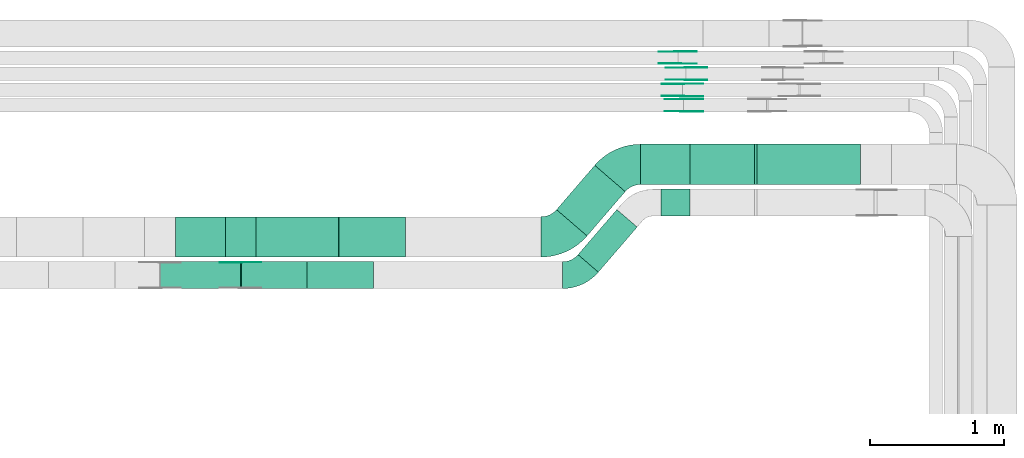
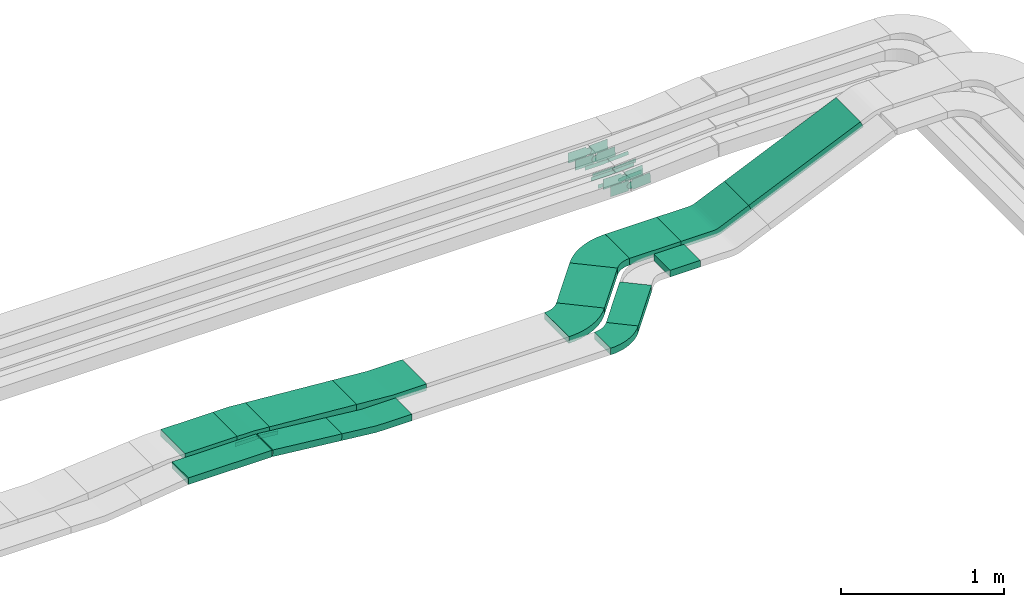
# One storey, part 20 of 28: 25 flow fittings, 9 flow segments.
"""IFC2X3 building model written with IfcOpenShell, lengths in millimetres."""

from ifc_helpers import new_model, entity, si_unit, converted_unit, derived_unit, direction, frame, frame_2d, origin, origin_2d_with_axis, place, context, subcontext, project, spatial, polyline, circle_curve, parameter, trimmed, segment, composite_curve, rectangle, outline, extrude, source, transform, mapped, material, type_object, type_shapes, element, save


model = new_model("IFC2X3")

# Units and contexts
model_context = context("Model", 3, precision=0.01, world=origin(), true_north=direction((6.12303176911189e-17, 1.0)))
body_context = subcontext(model_context, "Body", "Model", "MODEL_VIEW")
ifc_project = project(units=[si_unit("LENGTHUNIT", "METRE", prefix="MILLI"), si_unit("AREAUNIT", "SQUARE_METRE"), si_unit("VOLUMEUNIT", "CUBIC_METRE"), converted_unit("PLANEANGLEUNIT", "DEGREE", entity("IfcRatioMeasure", 0.0174532925199433), si_unit("PLANEANGLEUNIT", "RADIAN"), dimensions=[0, 0, 0, 0, 0, 0, 0]), si_unit("MASSUNIT", "GRAM", prefix="KILO"), derived_unit("MASSDENSITYUNIT", [(si_unit("MASSUNIT", "GRAM", prefix="KILO"), 1), (si_unit("LENGTHUNIT", "METRE"), -3)]), derived_unit("MOMENTOFINERTIAUNIT", [(si_unit("LENGTHUNIT", "METRE"), 4)]), si_unit("TIMEUNIT", "SECOND"), si_unit("FREQUENCYUNIT", "HERTZ"), si_unit("THERMODYNAMICTEMPERATUREUNIT", "DEGREE_CELSIUS"), derived_unit("THERMALTRANSMITTANCEUNIT", [(si_unit("MASSUNIT", "GRAM", prefix="KILO"), 1), (si_unit("THERMODYNAMICTEMPERATUREUNIT", "KELVIN"), -1), (si_unit("TIMEUNIT", "SECOND"), -3)]), derived_unit("VOLUMETRICFLOWRATEUNIT", [(si_unit("LENGTHUNIT", "METRE"), 3), (si_unit("TIMEUNIT", "SECOND"), -1)]), derived_unit("MASSFLOWRATEUNIT", [(si_unit("MASSUNIT", "GRAM", prefix="KILO"), 1), (si_unit("TIMEUNIT", "SECOND"), -1)]), derived_unit("ROTATIONALFREQUENCYUNIT", [(si_unit("TIMEUNIT", "SECOND"), -1)]), si_unit("ELECTRICCURRENTUNIT", "AMPERE"), si_unit("ELECTRICVOLTAGEUNIT", "VOLT"), si_unit("POWERUNIT", "WATT"), si_unit("FORCEUNIT", "NEWTON", prefix="KILO"), si_unit("ILLUMINANCEUNIT", "LUX"), si_unit("LUMINOUSFLUXUNIT", "LUMEN"), si_unit("LUMINOUSINTENSITYUNIT", "CANDELA"), derived_unit("USERDEFINED", [(si_unit("MASSUNIT", "GRAM", prefix="KILO"), -1), (si_unit("LENGTHUNIT", "METRE"), -2), (si_unit("TIMEUNIT", "SECOND"), 3), (si_unit("LUMINOUSFLUXUNIT", "LUMEN"), 1)]), derived_unit("LINEARVELOCITYUNIT", [(si_unit("LENGTHUNIT", "METRE"), 1), (si_unit("TIMEUNIT", "SECOND"), -1)]), si_unit("PRESSUREUNIT", "PASCAL"), derived_unit("USERDEFINED", [(si_unit("LENGTHUNIT", "METRE"), -2), (si_unit("MASSUNIT", "GRAM", prefix="KILO"), 1), (si_unit("TIMEUNIT", "SECOND"), -2)]), derived_unit("LINEARFORCEUNIT", [(si_unit("MASSUNIT", "GRAM", prefix="KILO"), 1), (si_unit("LENGTHUNIT", "METRE"), 1), (si_unit("TIMEUNIT", "SECOND"), -2), (si_unit("LENGTHUNIT", "METRE"), -1)]), derived_unit("PLANARFORCEUNIT", [(si_unit("MASSUNIT", "GRAM", prefix="KILO"), 1), (si_unit("LENGTHUNIT", "METRE"), 1), (si_unit("TIMEUNIT", "SECOND"), -2), (si_unit("LENGTHUNIT", "METRE"), -2)])], contexts=[model_context])

# Site, building, storey
site_placement = place(None, origin())
site = spatial("IfcSite", under=ifc_project, at=site_placement, CompositionType="ELEMENT")
building_placement = place(site_placement, origin())
building = spatial("IfcBuilding", under=site, at=building_placement, CompositionType="ELEMENT")
storey_placement = place(building_placement, frame((0.0, 0.0, 15900.0)))
storey = spatial("IfcBuildingStorey", under=building, at=storey_placement, CompositionType="ELEMENT", Elevation=15900.0)

# Flow segments
cable_carrier_segment_type = type_object("IfcCableCarrierSegmentType", PredefinedType="CABLETRAYSEGMENT")
flow_segment_1_placement = place(storey_placement, frame((54513.74, 14435.03, 2586.3)))
element("IfcFlowSegment", 1, at=flow_segment_1_placement, inside=storey, type_object=cable_carrier_segment_type, context=body_context, shape_type="SweptSolid", body=[
    extrude(rectangle(XDim=370.439682383992, YDim=300.000000000001, at=origin_2d_with_axis()), frame((185.22, 150.0, 0.0), z_axis=(0.0, 0.0, 1.0), x_axis=(-1.0, 0.0, 0.0)), (0.0, 0.0, 1.0), 50.0000000000016),
])
flow_segment_2_placement = place(storey_placement, frame((54402.55, 14200.03, 2586.3)))
element("IfcFlowSegment", 2, at=flow_segment_2_placement, inside=storey, type_object=cable_carrier_segment_type, context=body_context, shape_type="SweptSolid", body=[
    extrude(rectangle(XDim=593.343795790922, YDim=199.999999999998, at=origin_2d_with_axis()), frame((296.67, 100.0, 0.0)), (0.0, 0.0, 1.0), 50.0000000000016),
])
flow_segment_3_placement = place(storey_placement, frame((54998.3, 14200.03, 2535.71)))
element("IfcFlowSegment", 3, at=flow_segment_3_placement, inside=storey, type_object=cable_carrier_segment_type, context=body_context, shape_type="SweptSolid", body=[
    extrude(rectangle(XDim=49.9999999999982, YDim=200.000000000002, at=frame_2d((0.0, 0.0), x_axis=(0.0, 1.0))), frame((2.56, 100.0, 75.33), z_axis=(0.994726726442406, 0.0, -0.102560907275502), x_axis=(0.0, 1.0, 0.0)), (0.0, 0.0, 1.0), 492.05634317635),
])
flow_segment_4_placement = place(storey_placement, frame((55110.3, 14435.03, 2529.43)))
element("IfcFlowSegment", 4, at=flow_segment_4_placement, inside=storey, type_object=cable_carrier_segment_type, context=body_context, shape_type="SweptSolid", body=[
    extrude(rectangle(XDim=49.9999999999992, YDim=300.000000000001, at=origin_2d_with_axis()), frame((1.94, 150.0, 73.0), z_axis=(0.996983046674374, 0.0, -0.0776196150717272), x_axis=(0.0776196150717272, 0.0, 0.996983046674374)), (0.0, 0.0, 1.0), 619.357557407488),
])
flow_segment_5_placement = place(storey_placement, frame((57977.73, 14975.03, 2510.0)))
element("IfcFlowSegment", 5, at=flow_segment_5_placement, inside=storey, type_object=cable_carrier_segment_type, context=body_context, shape_type="SweptSolid", body=[
    extrude(rectangle(XDim=365.580974619781, YDim=300.000000000001, at=origin_2d_with_axis()), frame((182.79, 150.0, 0.0)), (0.0, 0.0, 1.0), 50.0000000000016),
])
flow_segment_6_placement = place(storey_placement, frame((58129.86, 14740.03, 2510.0)))
element("IfcFlowSegment", 6, at=flow_segment_6_placement, inside=storey, type_object=cable_carrier_segment_type, context=body_context, shape_type="SweptSolid", body=[
    extrude(rectangle(XDim=213.446304058507, YDim=200.000000000002, at=origin_2d_with_axis()), frame((106.72, 100.0, 0.0), z_axis=(0.0, 0.0, 1.0), x_axis=(-1.0, 0.0, 0.0)), (0.0, 0.0, 1.0), 50.0000000000016),
])
flow_segment_7_placement = place(storey_placement, frame((58823.1, 14975.03, 2615.54)))
element("IfcFlowSegment", 7, at=flow_segment_7_placement, inside=storey, type_object=cable_carrier_segment_type, context=body_context, shape_type="SweptSolid", body=[
    extrude(rectangle(XDim=50.0000000000058, YDim=300.000000000001, at=frame_2d((0.0, 0.0), x_axis=(0.0, 1.0))), frame((10.1, 150.0, 22.87), z_axis=(0.914695360334615, 0.0, 0.404144030986887), x_axis=(0.0, 1.0, 0.0)), (0.0, 0.0, 1.0), 866.474738056523),
])
flow_segment_8_placement = place(storey_placement, frame((57350.89, 14592.13, 2510.0)))
element("IfcFlowSegment", 8, at=flow_segment_8_placement, inside=storey, type_object=cable_carrier_segment_type, context=body_context, shape_type="SweptSolid", body=[
    extrude(rectangle(XDim=435.530076428594, YDim=300.000000000003, at=origin_2d_with_axis()), frame((255.77, 262.89, 0.0), z_axis=(0.0, 0.0, 1.0), x_axis=(-0.652556674980556, -0.757739919720692, 0.0)), (0.0, 0.0, 1.0), 50.0000000000016),
])
flow_segment_9_placement = place(storey_placement, frame((57510.67, 14322.39, 2510.0)))
element("IfcFlowSegment", 9, at=flow_segment_9_placement, inside=storey, type_object=cable_carrier_segment_type, context=body_context, shape_type="SweptSolid", body=[
    extrude(rectangle(XDim=443.176120125961, YDim=200.000000000008, at=origin_2d_with_axis()), frame((220.37, 233.16, 0.0), z_axis=(0.0, 0.0, 1.0), x_axis=(0.652556674980505, 0.757739919720736, 0.0)), (0.0, 0.0, 1.0), 50.0000000000016),
])

# Flow fittings
ifc_material_1 = material(Name="G")
cable_carrier_fitting_type_1 = type_object("IfcCableCarrierFittingType", PredefinedType="NOTDEFINED", material=ifc_material_1)
shared_shape_1 = source(origin(), body_context, "Body", "SweptSolid", [
    extrude(outline(composite_curve([segment(trimmed(circle_curve(frame_2d((-44.59, 0.0), x_axis=(1.0, 0.0)), 12.5), [parameter(90.0000000000007)], [parameter(270.0)], True, "PARAMETER"), True, "CONTINUOUS"), segment(polyline([(-44.59, -12.5), (-33.09, -12.5)]), True, "CONTINUOUS"), segment(polyline([(-33.09, -12.5), (-31.23, -14.5)]), True, "CONTINUOUS"), segment(polyline([(-31.23, -14.5), (108.91, -14.5)]), True, "CONTINUOUS"), segment(polyline([(108.91, -14.5), (108.91, 14.5)]), True, "CONTINUOUS"), segment(polyline([(108.91, 14.5), (-31.23, 14.5)]), True, "CONTINUOUS"), segment(polyline([(-31.23, 14.5), (-33.09, 12.5)]), True, "CONTINUOUS"), segment(polyline([(-33.09, 12.5), (-44.59, 12.5)]), True, "CONTINUOUS")], self_intersect=False)), frame((44.59, 0.0, 0.0), z_axis=(0.0, 0.0, -1.0), x_axis=(1.0, 0.0, 0.0)), (0.0, 0.0, -1.0), 2.0),
])
type_shapes(cable_carrier_fitting_type_1, [shared_shape_1])
flow_fitting_1_placement = place(storey_placement, frame((58317.82, 15754.0, 2642.36), z_axis=(0.0, -1.0, 0.0), x_axis=(0.998226574623013, 0.0, 0.0595290325505655)))
element("IfcFlowFitting", 10, at=flow_fitting_1_placement, inside=storey, type_object=cable_carrier_fitting_type_1, material=ifc_material_1, context=body_context, shape_type="MappedRepresentation", body=[
    mapped(shared_shape_1, transform((0.0, 0.0, 0.0), scale=1.0)),
])
cable_carrier_fitting_type_2 = type_object("IfcCableCarrierFittingType", PredefinedType="NOTDEFINED", material=ifc_material_1)
type_shapes(cable_carrier_fitting_type_2, [shared_shape_1])
flow_fitting_2_placement = place(storey_placement, frame((58317.82, 15842.92, 2642.36), z_axis=(0.0, 1.0, 0.0), x_axis=(-1.0, 0.0, 0.0)))
element("IfcFlowFitting", 11, at=flow_fitting_2_placement, inside=storey, type_object=cable_carrier_fitting_type_2, material=ifc_material_1, context=body_context, shape_type="MappedRepresentation", body=[
    mapped(shared_shape_1, transform((0.0, 0.0, 0.0), scale=1.0)),
])
flow_fitting_3_placement = place(storey_placement, frame((58289.07, 15634.0, 2642.36), z_axis=(0.0, -1.0, 0.0), x_axis=(0.998794992173109, 0.0, 0.0490771190058922)))
element("IfcFlowFitting", 12, at=flow_fitting_3_placement, inside=storey, type_object=cable_carrier_fitting_type_1, material=ifc_material_1, context=body_context, shape_type="MappedRepresentation", body=[
    mapped(shared_shape_1, transform((0.0, 0.0, 0.0), scale=1.0)),
])
flow_fitting_4_placement = place(storey_placement, frame((58289.07, 15722.92, 2642.36), z_axis=(0.0, 1.0, 0.0), x_axis=(-1.0, 0.0, 0.0)))
element("IfcFlowFitting", 13, at=flow_fitting_4_placement, inside=storey, type_object=cable_carrier_fitting_type_2, material=ifc_material_1, context=body_context, shape_type="MappedRepresentation", body=[
    mapped(shared_shape_1, transform((0.0, 0.0, 0.0), scale=1.0)),
])
flow_fitting_5_placement = place(storey_placement, frame((54998.38, 14395.49, 2611.3), z_axis=(0.0, 1.0, 0.0), x_axis=(0.994726726442407, 0.0, -0.1025609072755)))
element("IfcFlowFitting", 14, at=flow_fitting_5_placement, inside=storey, type_object=cable_carrier_fitting_type_1, material=ifc_material_1, context=body_context, shape_type="MappedRepresentation", body=[
    mapped(shared_shape_1, transform((0.0, 0.0, 0.0), scale=1.0)),
])
cable_carrier_fitting_type_3 = type_object("IfcCableCarrierFittingType", PredefinedType="NOTDEFINED", material=ifc_material_1)
shared_shape_2 = source(origin(), body_context, "Body", "SweptSolid", [
    extrude(outline(composite_curve([segment(trimmed(circle_curve(frame_2d((-44.59, 0.0), x_axis=(1.0, 0.0)), 12.5), [parameter(90.0000000000007)], [parameter(270.0)], True, "PARAMETER"), True, "CONTINUOUS"), segment(polyline([(-44.59, -12.5), (-33.09, -12.5)]), True, "CONTINUOUS"), segment(polyline([(-33.09, -12.5), (-31.23, -14.5)]), True, "CONTINUOUS"), segment(polyline([(-31.23, -14.5), (108.91, -14.5)]), True, "CONTINUOUS"), segment(polyline([(108.91, -14.5), (108.91, 14.5)]), True, "CONTINUOUS"), segment(polyline([(108.91, 14.5), (-31.23, 14.5)]), True, "CONTINUOUS"), segment(polyline([(-31.23, 14.5), (-33.09, 12.5)]), True, "CONTINUOUS"), segment(polyline([(-33.09, 12.5), (-44.59, 12.5)]), True, "CONTINUOUS")], self_intersect=False)), frame((44.59, 0.0, 0.0)), (0.0, 0.0, 1.0), 2.0),
])
type_shapes(cable_carrier_fitting_type_3, [shared_shape_2])
flow_fitting_6_placement = place(storey_placement, frame((58317.82, 15844.92, 2642.36), z_axis=(0.0, 1.0, 0.0), x_axis=(0.998226574623013, 0.0, 0.0595290325505655)))
element("IfcFlowFitting", 15, at=flow_fitting_6_placement, inside=storey, type_object=cable_carrier_fitting_type_3, material=ifc_material_1, context=body_context, shape_type="MappedRepresentation", body=[
    mapped(shared_shape_2, transform((0.0, 0.0, 0.0), scale=1.0)),
])
cable_carrier_fitting_type_4 = type_object("IfcCableCarrierFittingType", PredefinedType="NOTDEFINED", material=ifc_material_1)
type_shapes(cable_carrier_fitting_type_4, [shared_shape_2])
flow_fitting_7_placement = place(storey_placement, frame((58317.82, 15756.0, 2642.36), z_axis=(0.0, -1.0, 0.0), x_axis=(-1.0, 0.0, 0.0)))
element("IfcFlowFitting", 16, at=flow_fitting_7_placement, inside=storey, type_object=cable_carrier_fitting_type_4, material=ifc_material_1, context=body_context, shape_type="MappedRepresentation", body=[
    mapped(shared_shape_2, transform((0.0, 0.0, 0.0), scale=1.0)),
])
flow_fitting_8_placement = place(storey_placement, frame((58289.07, 15724.92, 2642.36), z_axis=(0.0, 1.0, 0.0), x_axis=(0.998794992173109, 0.0, 0.0490771190058922)))
element("IfcFlowFitting", 17, at=flow_fitting_8_placement, inside=storey, type_object=cable_carrier_fitting_type_3, material=ifc_material_1, context=body_context, shape_type="MappedRepresentation", body=[
    mapped(shared_shape_2, transform((0.0, 0.0, 0.0), scale=1.0)),
])
for number, where, z_axis, x_axis in (
    (18, (58289.07, 15636.0, 2642.36), (0.0, -1.0, 0.0), (-1.0, 0.0, 0.0)),
    (19, (54998.38, 14393.49, 2611.3), (0.0, 1.0, 0.0), (-1.0, 0.0, 0.0)),
):
    element("IfcFlowFitting", number, at=place(storey_placement, frame(where, z_axis=z_axis, x_axis=x_axis)), inside=storey, type_object=cable_carrier_fitting_type_4, material=ifc_material_1, context=body_context, shape_type="MappedRepresentation", body=[
        mapped(shared_shape_2, transform((0.0, 0.0, 0.0), scale=1.0)),
    ])
cable_carrier_fitting_type_5 = type_object("IfcCableCarrierFittingType", PredefinedType="NOTDEFINED", material=ifc_material_1)
shared_shape_3 = source(origin(), body_context, "Body", "SweptSolid", [
    extrude(outline(composite_curve([segment(trimmed(circle_curve(frame_2d((-41.47, 0.0), x_axis=(1.0, 0.0)), 25.0), [parameter(90.0000000000007)], [parameter(270.0)], True, "PARAMETER"), True, "CONTINUOUS"), segment(polyline([(-41.47, -25.0), (-29.97, -25.0)]), True, "CONTINUOUS"), segment(polyline([(-29.97, -25.0), (-28.1, -38.5)]), True, "CONTINUOUS"), segment(polyline([(-28.1, -38.5), (99.53, -38.5)]), True, "CONTINUOUS"), segment(polyline([(99.53, -38.5), (99.53, 38.5)]), True, "CONTINUOUS"), segment(polyline([(99.53, 38.5), (-28.1, 38.5)]), True, "CONTINUOUS"), segment(polyline([(-28.1, 38.5), (-29.97, 25.0)]), True, "CONTINUOUS"), segment(polyline([(-29.97, 25.0), (-41.47, 25.0)]), True, "CONTINUOUS")], self_intersect=False)), frame((41.47, 0.0, 0.0), z_axis=(0.0, 0.0, -1.0), x_axis=(1.0, 0.0, 0.0)), (0.0, 0.0, -1.0), 2.0),
])
type_shapes(cable_carrier_fitting_type_5, [shared_shape_3])
flow_fitting_9_placement = place(storey_placement, frame((58298.49, 15519.53, 2667.03), z_axis=(0.0, -1.0, 0.0), x_axis=(0.997626423978682, 0.0, 0.0688586826733382)))
element("IfcFlowFitting", 20, at=flow_fitting_9_placement, inside=storey, type_object=cable_carrier_fitting_type_5, material=ifc_material_1, context=body_context, shape_type="MappedRepresentation", body=[
    mapped(shared_shape_3, transform((0.0, 0.0, 0.0), scale=1.0)),
])
cable_carrier_fitting_type_6 = type_object("IfcCableCarrierFittingType", PredefinedType="NOTDEFINED", material=ifc_material_1)
type_shapes(cable_carrier_fitting_type_6, [shared_shape_3])
flow_fitting_10_placement = place(storey_placement, frame((58298.49, 15608.45, 2667.03), z_axis=(0.0, 1.0, 0.0), x_axis=(-1.0, 0.0, 0.0)))
element("IfcFlowFitting", 21, at=flow_fitting_10_placement, inside=storey, type_object=cable_carrier_fitting_type_6, material=ifc_material_1, context=body_context, shape_type="MappedRepresentation", body=[
    mapped(shared_shape_3, transform((0.0, 0.0, 0.0), scale=1.0)),
])
flow_fitting_11_placement = place(storey_placement, frame((58253.36, 15874.53, 2665.0), z_axis=(0.0, -1.0, 0.0), x_axis=(0.999143050018218, 0.0, 0.0413904046886741)))
element("IfcFlowFitting", 22, at=flow_fitting_11_placement, inside=storey, type_object=cable_carrier_fitting_type_5, material=ifc_material_1, context=body_context, shape_type="MappedRepresentation", body=[
    mapped(shared_shape_3, transform((0.0, 0.0, 0.0), scale=1.0)),
])
flow_fitting_12_placement = place(storey_placement, frame((58253.36, 15963.45, 2665.0), z_axis=(0.0, 1.0, 0.0), x_axis=(-1.0, 0.0, 0.0)))
element("IfcFlowFitting", 23, at=flow_fitting_12_placement, inside=storey, type_object=cable_carrier_fitting_type_6, material=ifc_material_1, context=body_context, shape_type="MappedRepresentation", body=[
    mapped(shared_shape_3, transform((0.0, 0.0, 0.0), scale=1.0)),
])
cable_carrier_fitting_type_7 = type_object("IfcCableCarrierFittingType", PredefinedType="NOTDEFINED", material=ifc_material_1)
shared_shape_4 = source(origin(), body_context, "Body", "SweptSolid", [
    extrude(outline(composite_curve([segment(trimmed(circle_curve(frame_2d((-41.47, 0.0), x_axis=(1.0, 0.0)), 25.0), [parameter(90.0000000000007)], [parameter(270.0)], True, "PARAMETER"), True, "CONTINUOUS"), segment(polyline([(-41.47, -25.0), (-29.97, -25.0)]), True, "CONTINUOUS"), segment(polyline([(-29.97, -25.0), (-28.1, -38.5)]), True, "CONTINUOUS"), segment(polyline([(-28.1, -38.5), (99.53, -38.5)]), True, "CONTINUOUS"), segment(polyline([(99.53, -38.5), (99.53, 38.5)]), True, "CONTINUOUS"), segment(polyline([(99.53, 38.5), (-28.1, 38.5)]), True, "CONTINUOUS"), segment(polyline([(-28.1, 38.5), (-29.97, 25.0)]), True, "CONTINUOUS"), segment(polyline([(-29.97, 25.0), (-41.47, 25.0)]), True, "CONTINUOUS")], self_intersect=False)), frame((41.47, 0.0, 0.0)), (0.0, 0.0, 1.0), 2.0),
])
type_shapes(cable_carrier_fitting_type_7, [shared_shape_4])
flow_fitting_13_placement = place(storey_placement, frame((58298.49, 15610.45, 2667.03), z_axis=(0.0, 1.0, 0.0), x_axis=(0.997626423978682, 0.0, 0.0688586826733382)))
element("IfcFlowFitting", 24, at=flow_fitting_13_placement, inside=storey, type_object=cable_carrier_fitting_type_7, material=ifc_material_1, context=body_context, shape_type="MappedRepresentation", body=[
    mapped(shared_shape_4, transform((0.0, 0.0, 0.0), scale=1.0)),
])
cable_carrier_fitting_type_8 = type_object("IfcCableCarrierFittingType", PredefinedType="NOTDEFINED", material=ifc_material_1)
type_shapes(cable_carrier_fitting_type_8, [shared_shape_4])
flow_fitting_14_placement = place(storey_placement, frame((58298.49, 15521.53, 2667.03), z_axis=(0.0, -1.0, 0.0), x_axis=(-1.0, 0.0, 0.0)))
element("IfcFlowFitting", 25, at=flow_fitting_14_placement, inside=storey, type_object=cable_carrier_fitting_type_8, material=ifc_material_1, context=body_context, shape_type="MappedRepresentation", body=[
    mapped(shared_shape_4, transform((0.0, 0.0, 0.0), scale=1.0)),
])
flow_fitting_15_placement = place(storey_placement, frame((58253.36, 15965.45, 2665.0), z_axis=(0.0, 1.0, 0.0), x_axis=(0.999143050018218, 0.0, 0.0413904046886741)))
element("IfcFlowFitting", 26, at=flow_fitting_15_placement, inside=storey, type_object=cable_carrier_fitting_type_7, material=ifc_material_1, context=body_context, shape_type="MappedRepresentation", body=[
    mapped(shared_shape_4, transform((0.0, 0.0, 0.0), scale=1.0)),
])
flow_fitting_16_placement = place(storey_placement, frame((58253.36, 15876.53, 2665.0), z_axis=(0.0, -1.0, 0.0), x_axis=(-1.0, 0.0, 0.0)))
element("IfcFlowFitting", 27, at=flow_fitting_16_placement, inside=storey, type_object=cable_carrier_fitting_type_8, material=ifc_material_1, context=body_context, shape_type="MappedRepresentation", body=[
    mapped(shared_shape_4, transform((0.0, 0.0, 0.0), scale=1.0)),
])
ifc_material_2 = material()
cable_carrier_fitting_type_9 = type_object("IfcCableCarrierFittingType", Name="470_DKC_S5_CS 90 internal vertical angle:-", PredefinedType="NOTDEFINED", material=ifc_material_2)
shared_shape_5 = source(origin(), body_context, "Body", "SweptSolid", [
    extrude(outline(composite_curve([segment(polyline([(-249.04, -31.58), (-6.86, -31.58)]), True, "CONTINUOUS"), segment(trimmed(circle_curve(frame_2d((-6.86, 133.42), x_axis=(0.0, -1.0)), 164.999999999999), [parameter(0.0)], [parameter(5.88665809159337)], True, "PARAMETER"), True, "CONTINUOUS"), segment(polyline([(10.06, -30.71), (250.96, -5.87)]), True, "CONTINUOUS"), segment(polyline([(250.96, -5.87), (245.83, 43.87)]), True, "CONTINUOUS"), segment(polyline([(245.83, 43.87), (4.93, 19.03)]), True, "CONTINUOUS"), segment(trimmed(circle_curve(frame_2d((-6.86, 133.42), x_axis=(0.0, -1.0)), 114.999999999999), [parameter(0.0)], [parameter(5.88665809159337)], True, "PARAMETER"), False, "CONTINUOUS"), segment(polyline([(-6.86, 18.42), (-249.04, 18.42)]), True, "CONTINUOUS"), segment(polyline([(-249.04, 18.42), (-249.04, -31.58)]), True, "CONTINUOUS")], self_intersect=False)), frame((-0.34, 6.58, -100.0)), (0.0, 0.0, 1.0), 200.0),
])
type_shapes(cable_carrier_fitting_type_9, [shared_shape_5])
flow_fitting_17_placement = place(storey_placement, frame((55738.38, 14300.03, 2535.0), z_axis=(0.0, 1.0, 0.0), x_axis=(-1.0, 0.0, 0.0)))
element("IfcFlowFitting", 28, at=flow_fitting_17_placement, inside=storey, type_object=cable_carrier_fitting_type_9, material=ifc_material_2, Name="470_DKC_S5_CS 90 internal vertical angle:-", ObjectType="470_DKC_S5_CS 90 internal vertical angle:-", context=body_context, shape_type="MappedRepresentation", body=[
    mapped(shared_shape_5, transform((0.0, 0.0, 0.0), scale=1.0)),
])
cable_carrier_fitting_type_10 = type_object("IfcCableCarrierFittingType", Name="470_DKC_S5_CD 90 external vertical angle:-", PredefinedType="NOTDEFINED", material=ifc_material_2)
shared_shape_6 = source(origin(), body_context, "Body", "SweptSolid", [
    extrude(outline(composite_curve([segment(polyline([(-114.11, -27.34), (-6.32, -27.34)]), True, "CONTINUOUS"), segment(trimmed(circle_curve(frame_2d((-6.32, 162.66), x_axis=(0.0, -1.0)), 189.999999999999), [parameter(0.0)], [parameter(4.45175416362981)], True, "PARAMETER"), True, "CONTINUOUS"), segment(polyline([(8.43, -26.77), (115.89, -18.4)]), True, "CONTINUOUS"), segment(polyline([(115.89, -18.4), (112.01, 31.45)]), True, "CONTINUOUS"), segment(polyline([(112.01, 31.45), (4.54, 23.08)]), True, "CONTINUOUS"), segment(trimmed(circle_curve(frame_2d((-6.32, 162.66), x_axis=(0.0, -1.0)), 139.999999999999), [parameter(0.0)], [parameter(4.45175416362981)], True, "PARAMETER"), False, "CONTINUOUS"), segment(polyline([(-6.32, 22.66), (-114.11, 22.66)]), True, "CONTINUOUS"), segment(polyline([(-114.11, 22.66), (-114.11, -27.34)]), True, "CONTINUOUS")], self_intersect=False)), frame((-0.09, 2.34, -150.0)), (0.0, 0.0, 1.0), 300.0),
])
type_shapes(cable_carrier_fitting_type_10, [shared_shape_6])
flow_fitting_18_placement = place(storey_placement, frame((54998.38, 14585.03, 2611.3), z_axis=(0.0, 1.0, 0.0), x_axis=(1.0, 0.0, 0.0)))
element("IfcFlowFitting", 29, at=flow_fitting_18_placement, inside=storey, type_object=cable_carrier_fitting_type_10, material=ifc_material_2, Name="470_DKC_S5_CD 90 external vertical angle:-", ObjectType="470_DKC_S5_CD 90 external vertical angle:-", context=body_context, shape_type="MappedRepresentation", body=[
    mapped(shared_shape_6, transform((0.0, 0.0, 0.0), scale=1.0)),
])
cable_carrier_fitting_type_11 = type_object("IfcCableCarrierFittingType", Name="470_DKC_S5_CS 90 internal vertical angle:-", PredefinedType="NOTDEFINED", material=ifc_material_2)
shared_shape_7 = source(origin(), body_context, "Body", "SweptSolid", [
    extrude(outline(composite_curve([segment(polyline([(-249.21, -29.95), (-5.25, -29.95)]), True, "CONTINUOUS"), segment(trimmed(circle_curve(frame_2d((-5.25, 135.05), x_axis=(0.0, -1.0)), 164.999999999999), [parameter(0.0)], [parameter(4.45175416363027)], True, "PARAMETER"), True, "CONTINUOUS"), segment(polyline([(7.56, -29.45), (250.79, -10.51)]), True, "CONTINUOUS"), segment(polyline([(250.79, -10.51), (246.91, 39.34)]), True, "CONTINUOUS"), segment(polyline([(246.91, 39.34), (3.68, 20.4)]), True, "CONTINUOUS"), segment(trimmed(circle_curve(frame_2d((-5.25, 135.05), x_axis=(0.0, -1.0)), 114.999999999999), [parameter(0.0)], [parameter(4.45175416363027)], True, "PARAMETER"), False, "CONTINUOUS"), segment(polyline([(-5.25, 20.05), (-249.21, 20.05)]), True, "CONTINUOUS"), segment(polyline([(-249.21, 20.05), (-249.21, -29.95)]), True, "CONTINUOUS")], self_intersect=False)), frame((-0.19, 4.95, -150.0)), (0.0, 0.0, 1.0), 300.0),
])
type_shapes(cable_carrier_fitting_type_11, [shared_shape_7])
flow_fitting_19_placement = place(storey_placement, frame((55978.38, 14585.03, 2535.0), z_axis=(0.0, -1.0, 0.0), x_axis=(0.996983046674385, 0.0, -0.077619615071584)))
element("IfcFlowFitting", 30, at=flow_fitting_19_placement, inside=storey, type_object=cable_carrier_fitting_type_11, material=ifc_material_2, Name="470_DKC_S5_CS 90 internal vertical angle:-", ObjectType="470_DKC_S5_CS 90 internal vertical angle:-", context=body_context, shape_type="MappedRepresentation", body=[
    mapped(shared_shape_7, transform((0.0, 0.0, 0.0), scale=1.0)),
])
cable_carrier_fitting_type_12 = type_object("IfcCableCarrierFittingType", Name="470_DKC_S5_CS 90 internal vertical angle:-", PredefinedType="NOTDEFINED", material=ifc_material_2)
shared_shape_8 = source(origin(), body_context, "Body", "SweptSolid", [
    extrude(outline(composite_curve([segment(polyline([(-249.77, -53.84), (-23.46, -53.84)]), True, "CONTINUOUS"), segment(trimmed(circle_curve(frame_2d((-23.46, 111.16), x_axis=(0.0, -1.0)), 164.999999999999), [parameter(0.0)], [parameter(23.8374988354048)], True, "PARAMETER"), True, "CONTINUOUS"), segment(polyline([(43.22, -39.76), (250.23, 51.7)]), True, "CONTINUOUS"), segment(polyline([(250.23, 51.7), (230.02, 97.44)]), True, "CONTINUOUS"), segment(polyline([(230.02, 97.44), (23.01, 5.97)]), True, "CONTINUOUS"), segment(trimmed(circle_curve(frame_2d((-23.46, 111.16), x_axis=(0.0, -1.0)), 114.999999999999), [parameter(0.0)], [parameter(23.8374988354048)], True, "PARAMETER"), False, "CONTINUOUS"), segment(polyline([(-23.46, -3.84), (-249.77, -3.84)]), True, "CONTINUOUS"), segment(polyline([(-249.77, -3.84), (-249.77, -53.84)]), True, "CONTINUOUS")], self_intersect=False)), frame((-6.09, 28.84, -150.0)), (0.0, 0.0, 1.0), 300.0),
])
type_shapes(cable_carrier_fitting_type_12, [shared_shape_8])
flow_fitting_20_placement = place(storey_placement, frame((58599.17, 15125.03, 2535.0), z_axis=(0.0, -1.0, 0.0), x_axis=(1.0, 0.0, 0.0)))
element("IfcFlowFitting", 31, at=flow_fitting_20_placement, inside=storey, type_object=cable_carrier_fitting_type_12, material=ifc_material_2, Name="470_DKC_S5_CS 90 internal vertical angle:-", ObjectType="470_DKC_S5_CS 90 internal vertical angle:-", context=body_context, shape_type="MappedRepresentation", body=[
    mapped(shared_shape_8, transform((0.0, 0.0, 0.0), scale=1.0)),
])
cable_carrier_fitting_type_13 = type_object("IfcCableCarrierFittingType", Name="470_DKC_S5_Variable Angle Elbow 0-45:-", PredefinedType="NOTDEFINED", material=ifc_material_2)
shared_shape_9 = source(origin(), body_context, "Body", "SweptSolid", [
    extrude(outline(composite_curve([segment(polyline([(-114.57, -202.31), (-113.57, -202.31)]), True, "CONTINUOUS"), segment(trimmed(circle_curve(frame_2d((-113.57, 247.69), x_axis=(0.0, -1.0)), 450.0), [parameter(0.0)], [parameter(49.265357282271)], True, "PARAMETER"), True, "CONTINUOUS"), segment(polyline([(227.41, -45.96), (228.06, -45.2)]), True, "CONTINUOUS"), segment(polyline([(228.06, -45.2), (0.74, 150.57)]), True, "CONTINUOUS"), segment(polyline([(0.74, 150.57), (0.09, 149.81)]), True, "CONTINUOUS"), segment(trimmed(circle_curve(frame_2d((-113.57, 247.69), x_axis=(0.0, -1.0)), 150.0), [parameter(0.0)], [parameter(49.265357282271)], True, "PARAMETER"), False, "CONTINUOUS"), segment(polyline([(-113.57, 97.69), (-114.57, 97.69)]), True, "CONTINUOUS"), segment(polyline([(-114.57, 97.69), (-114.57, -202.31)]), True, "CONTINUOUS")], self_intersect=False)), frame((-23.98, 52.31, -25.0)), (0.0, 0.0, 1.0), 49.9999999999981),
])
type_shapes(cable_carrier_fitting_type_13, [shared_shape_9])
flow_fitting_21_placement = place(storey_placement, frame((57839.17, 15125.03, 2535.0), z_axis=(0.0, 0.0, 1.0), x_axis=(-1.0, 0.0, 0.0)))
element("IfcFlowFitting", 32, at=flow_fitting_21_placement, inside=storey, type_object=cable_carrier_fitting_type_13, material=ifc_material_2, Name="470_DKC_S5_Variable Angle Elbow 0-45:-", ObjectType="470_DKC_S5_Variable Angle Elbow 0-45:-", context=body_context, shape_type="MappedRepresentation", body=[
    mapped(shared_shape_9, transform((0.0, 0.0, 0.0), scale=1.0)),
])
flow_fitting_22_placement = place(storey_placement, frame((57374.13, 14585.03, 2535.0)))
element("IfcFlowFitting", 33, at=flow_fitting_22_placement, inside=storey, type_object=cable_carrier_fitting_type_13, material=ifc_material_2, Name="470_DKC_S5_Variable Angle Elbow 0-45:-", ObjectType="470_DKC_S5_Variable Angle Elbow 0-45:-", context=body_context, shape_type="MappedRepresentation", body=[
    mapped(shared_shape_9, transform((0.0, 0.0, 0.0), scale=1.0)),
])
cable_carrier_fitting_type_14 = type_object("IfcCableCarrierFittingType", Name="470_DKC_S5_Variable Angle Elbow 0-45:-", PredefinedType="NOTDEFINED", material=ifc_material_2)
shared_shape_10 = source(origin(), body_context, "Body", "SweptSolid", [
    extrude(outline(composite_curve([segment(polyline([(-95.63, -143.62), (-94.63, -143.62)]), True, "CONTINUOUS"), segment(trimmed(circle_curve(frame_2d((-94.63, 206.38), x_axis=(0.0, -1.0)), 350.0), [parameter(0.0)], [parameter(49.2653572822751)], True, "PARAMETER"), True, "CONTINUOUS"), segment(polyline([(170.58, -22.01), (171.23, -21.26)]), True, "CONTINUOUS"), segment(polyline([(171.23, -21.26), (19.68, 109.25)]), True, "CONTINUOUS"), segment(polyline([(19.68, 109.25), (19.03, 108.5)]), True, "CONTINUOUS"), segment(trimmed(circle_curve(frame_2d((-94.63, 206.38), x_axis=(0.0, -1.0)), 150.0), [parameter(0.0)], [parameter(49.2653572822751)], True, "PARAMETER"), False, "CONTINUOUS"), segment(polyline([(-94.63, 56.38), (-95.63, 56.38)]), True, "CONTINUOUS"), segment(polyline([(-95.63, 56.38), (-95.63, -143.62)]), True, "CONTINUOUS")], self_intersect=False)), frame((-20.0, 43.62, -25.0)), (0.0, 0.0, 1.0), 50.0000000000008),
])
type_shapes(cable_carrier_fitting_type_14, [shared_shape_10])
flow_fitting_23_placement = place(storey_placement, frame((57510.99, 14300.03, 2535.0)))
element("IfcFlowFitting", 34, at=flow_fitting_23_placement, inside=storey, type_object=cable_carrier_fitting_type_14, material=ifc_material_2, Name="470_DKC_S5_Variable Angle Elbow 0-45:-", ObjectType="470_DKC_S5_Variable Angle Elbow 0-45:-", context=body_context, shape_type="MappedRepresentation", body=[
    mapped(shared_shape_10, transform((0.0, 0.0, 0.0), scale=1.0)),
])

save(model, "model.ifc")
